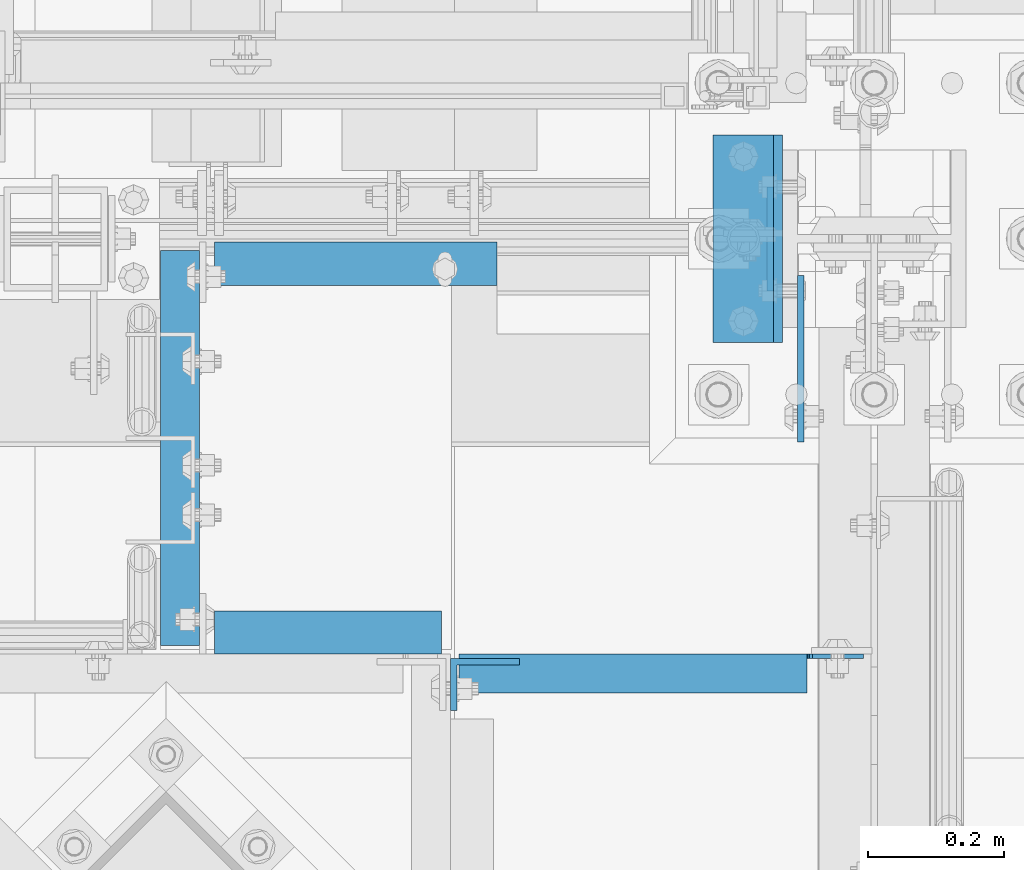
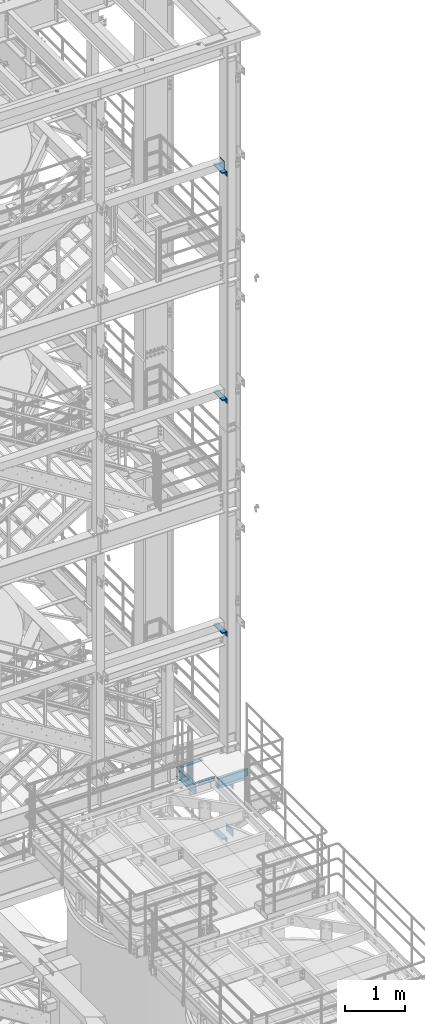
# One storey, part 1153 of 1876: 16 beams, 10 elements without a shape of their own.
"""IFC2X3 building model written with IfcOpenShell, lengths in millimetres."""

from ifc_helpers import new_model, si_unit, frame, origin_with_axes, place, context, subcontext, project, spatial, faceted_brep, material, type_object, element, aggregate, save


model = new_model("IFC2X3")

# Units and contexts
model_context = context("Model", 3, precision=1e-05, world=origin_with_axes())
body_context = subcontext(model_context, "Body", "Model", "MODEL_VIEW")
ifc_project = project(units=[si_unit("LENGTHUNIT", "METRE", prefix="MILLI"), si_unit("AREAUNIT", "SQUARE_METRE"), si_unit("VOLUMEUNIT", "CUBIC_METRE"), si_unit("MASSUNIT", "GRAM", prefix="KILO"), si_unit("TIMEUNIT", "SECOND"), si_unit("PLANEANGLEUNIT", "RADIAN"), si_unit("SOLIDANGLEUNIT", "STERADIAN"), si_unit("THERMODYNAMICTEMPERATUREUNIT", "DEGREE_CELSIUS"), si_unit("LUMINOUSINTENSITYUNIT", "LUMEN")], contexts=[model_context])

# Site, building, storey
site_placement = place(None, origin_with_axes())
site = spatial("IfcSite", under=ifc_project, at=site_placement, CompositionType="ELEMENT")
building_placement = place(site_placement, origin_with_axes())
building = spatial("IfcBuilding", under=site, at=building_placement, Name="Undefined", CompositionType="ELEMENT")
storey_placement = place(building_placement, origin_with_axes())
storey = spatial("IfcBuildingStorey", under=building, at=storey_placement, Name="Undefined", CompositionType="ELEMENT", Elevation=0.0)

# Assembly, beam
assembly_1_placement = place(storey_placement, origin_with_axes())
assembly_1 = element("IfcElementAssembly", 1, at=assembly_1_placement, inside=storey, Name="FRAME", AssemblyPlace="NOTDEFINED", PredefinedType="RIGID_FRAME")
ifc_material = material(Name="STEEL/A36")
beam_type_1 = type_object("IfcBeamType", PredefinedType="NOTDEFINED")
beam_1_placement = place(assembly_1_placement, frame((7467.60000019073, -7188.2, 19958.05), z_axis=(0.0, 0.0, -1.0), x_axis=(0.0, 1.0, 0.0)))
beam_1 = element("IfcBeam", 2, at=beam_1_placement, type_object=beam_type_1, material=ifc_material, Name="PLATE", context=body_context, shape_type="Brep", body=[
    faceted_brep([(0.0, 4.76249999999982, -76.1999999999998), (3.63797880709171e-12, 4.76249999999982, 76.1999969482422), (152.399993896484, 4.76250000000073, 76.1999969482422), (152.4, 4.76249999999982, -76.1999999999998), (3.63797880709171e-12, -4.76249999999982, 76.1999969482422), (152.399993896484, -4.76250000000073, 76.1999969482422), (0.0, -4.76249999999982, -76.1999999999998), (152.4, -4.76249999999982, -76.1999999999998)], [[[0, 1, 2, 3]], [[4, 5, 2, 1]], [[4, 6, 7, 5]], [[6, 0, 3, 7]], [[5, 7, 3, 2]], [[6, 4, 1, 0]]]),
])

# Assembly, beams
assembly_2_placement = place(storey_placement, origin_with_axes())
assembly_2 = element("IfcElementAssembly", 3, at=assembly_2_placement, inside=storey, Name="COLUMN", AssemblyPlace="NOTDEFINED", PredefinedType="RIGID_FRAME")
beam_2_placement = place(assembly_2_placement, frame((7512.05000642308, -7410.44999604537, 6483.35), z_axis=(0.0, 0.0, -1.0), x_axis=(0.0, 1.0, 0.0)))
beam_2 = element("IfcBeam", 4, at=beam_2_placement, type_object=beam_type_1, material=ifc_material, Name="PLATE", context=body_context, shape_type="Brep", body=[
    faceted_brep([(0.0, 4.76249999999982, -76.1999999999998), (3.63797880709171e-12, 4.76249999999982, 76.1999969482422), (244.474996168343, 4.76249999995889, 76.1999999999998), (244.474996168343, 4.76249999995889, -76.1999999999998), (3.63797880709171e-12, -4.76249999999982, 76.1999969482422), (244.474996168342, -4.76250000004075, 76.1999999999998), (0.0, -4.76249999999982, -76.1999999999998), (244.474996168342, -4.76250000004075, -76.1999999999998)], [[[0, 1, 2, 3]], [[1, 4, 5, 2]], [[4, 6, 7, 5]], [[6, 0, 3, 7]], [[5, 7, 3, 2]], [[6, 4, 1, 0]]]),
])
beam_3_placement = place(assembly_2_placement, frame((7512.05000642308, -7410.44999604537, 7454.9), z_axis=(0.0, 0.0, -1.0), x_axis=(0.0, 1.0, 0.0)))
beam_3 = element("IfcBeam", 5, at=beam_3_placement, type_object=beam_type_1, material=ifc_material, Name="PLATE", context=body_context, shape_type="Brep", body=[
    faceted_brep([(0.0, 4.76249999999982, -76.1999999999998), (3.63797880709171e-12, 4.76249999999982, 76.1999969482422), (244.474996168343, 4.76249999995889, 76.1999999999998), (244.474996168343, 4.76249999995889, -76.1999999999998), (3.63797880709171e-12, -4.76249999999982, 76.1999969482422), (244.474996168342, -4.76250000004075, 76.1999999999998), (0.0, -4.76249999999982, -76.1999999999998), (244.474996168342, -4.76250000004075, -76.1999999999998)], [[[0, 1, 2, 3]], [[1, 4, 5, 2]], [[4, 6, 7, 5]], [[6, 0, 3, 7]], [[5, 7, 3, 2]], [[6, 4, 1, 0]]]),
])

# Beam
beam_type_2 = type_object("IfcBeamType", PredefinedType="NOTDEFINED")
beam_4_placement = place(assembly_1_placement, frame((7427.91250019074, -7264.4, 19877.0875), z_axis=(-1.0, 0.0, 0.0), x_axis=(0.0, 1.0, 0.0)))
beam_4 = element("IfcBeam", 6, at=beam_4_placement, type_object=beam_type_2, material=ifc_material, Name="PLATE", context=body_context, shape_type="Brep", body=[
    faceted_brep([(0.0, 4.76250000000073, -44.4499999999998), (0.0, 4.76250000000073, 44.4499999999998), (304.799999999999, 4.76250000000073, 44.4499999999998), (304.799999999999, 4.76250000000073, -44.4499999999998), (0.0, -4.76250000000073, 44.4499999999998), (304.799999999999, -4.76250000000073, 44.4499999999998), (0.0, -4.76250000000073, -44.4499999999998), (304.799999999999, -4.76250000000073, -44.4499999999998)], [[[0, 1, 2, 3]], [[1, 4, 5, 2]], [[4, 6, 7, 5]], [[6, 0, 3, 7]], [[5, 7, 3, 2]], [[6, 4, 1, 0]]]),
])

aggregate(assembly_1, [beam_1, beam_4])

# Assembly, beam
assembly_3_placement = place(storey_placement, origin_with_axes())
assembly_3 = element("IfcElementAssembly", 7, at=assembly_3_placement, inside=storey, Name="FRAME", AssemblyPlace="NOTDEFINED", PredefinedType="RIGID_FRAME")
beam_5_placement = place(assembly_3_placement, frame((7427.91250019074, -7264.4, 15254.2875), z_axis=(-1.0, 0.0, 0.0), x_axis=(0.0, 1.0, 0.0)))
beam_5 = element("IfcBeam", 8, at=beam_5_placement, type_object=beam_type_2, material=ifc_material, Name="PLATE", context=body_context, shape_type="Brep", body=[
    faceted_brep([(0.0, 4.76250000000073, -44.4499999999998), (0.0, 4.76250000000073, 44.4499999999998), (304.799999999999, 4.76250000000073, 44.4499999999998), (304.799999999999, 4.76250000000073, -44.4499999999998), (0.0, -4.76250000000073, 44.4499999999998), (304.799999999999, -4.76250000000073, 44.4499999999998), (0.0, -4.76250000000073, -44.4499999999998), (304.799999999999, -4.76250000000073, -44.4499999999998)], [[[0, 1, 2, 3]], [[1, 4, 5, 2]], [[4, 6, 7, 5]], [[6, 0, 3, 7]], [[5, 7, 3, 2]], [[6, 4, 1, 0]]]),
])
aggregate(assembly_3, [beam_5])

assembly_4_placement = place(storey_placement, origin_with_axes())
assembly_4 = element("IfcElementAssembly", 9, at=assembly_4_placement, inside=storey, Name="FRAME", AssemblyPlace="NOTDEFINED", PredefinedType="RIGID_FRAME")
beam_6_placement = place(assembly_4_placement, frame((7427.93174253958, -7264.4, 10517.1875), z_axis=(-1.0, 0.0, 0.0), x_axis=(0.0, 1.0, 0.0)))
beam_6 = element("IfcBeam", 10, at=beam_6_placement, type_object=beam_type_2, material=ifc_material, Name="PLATE", context=body_context, shape_type="Brep", body=[
    faceted_brep([(0.0, 4.76250000000073, -44.4499999999998), (0.0, 4.76250000000073, 44.4499999999998), (304.799999999999, 4.76250000000073, 44.4499999999998), (304.799999999999, 4.76250000000073, -44.4499999999998), (0.0, -4.76250000000073, 44.4499999999998), (304.799999999999, -4.76250000000073, 44.4499999999998), (0.0, -4.76250000000073, -44.4499999999998), (304.799999999999, -4.76250000000073, -44.4499999999998)], [[[0, 1, 2, 3]], [[1, 4, 5, 2]], [[4, 6, 7, 5]], [[6, 0, 3, 7]], [[5, 7, 3, 2]], [[6, 4, 1, 0]]]),
])
aggregate(assembly_4, [beam_6])

assembly_5_placement = place(storey_placement, origin_with_axes())
assembly_5 = element("IfcElementAssembly", 11, at=assembly_5_placement, inside=storey, Name="FRAME", AssemblyPlace="NOTDEFINED", PredefinedType="RIGID_FRAME")
beam_7_placement = place(assembly_5_placement, frame((7427.89325746042, -7264.4, 6326.18751063849), z_axis=(-1.0, 0.0, 0.0), x_axis=(0.0, 1.0, 0.0)))
beam_7 = element("IfcBeam", 12, at=beam_7_placement, type_object=beam_type_2, material=ifc_material, Name="PLATE", context=body_context, shape_type="Brep", body=[
    faceted_brep([(0.0, 4.76250000000073, -44.4499999999998), (0.0, 4.76250000000073, 44.4499999999998), (304.799999999999, 4.76250000000073, 44.4499999999998), (304.799999999999, 4.76250000000073, -44.4499999999998), (0.0, -4.76250000000073, 44.4499999999998), (304.799999999999, -4.76250000000073, 44.4499999999998), (0.0, -4.76250000000073, -44.4499999999998), (304.799999999999, -4.76250000000073, -44.4499999999998)], [[[0, 1, 2, 3]], [[1, 4, 5, 2]], [[4, 6, 7, 5]], [[6, 0, 3, 7]], [[5, 7, 3, 2]], [[6, 4, 1, 0]]]),
])
aggregate(assembly_5, [beam_7])

# Assembly, beams
assembly_6_placement = place(storey_placement, origin_with_axes())
assembly_6 = element("IfcElementAssembly", 13, at=assembly_6_placement, inside=storey, Name="COLUMN", AssemblyPlace="NOTDEFINED", PredefinedType="RIGID_FRAME")
beam_type_3 = type_object("IfcBeamType", Name="L4X4X3/8", PredefinedType="NOTDEFINED")
beam_8_placement = place(assembly_6_placement, frame((7434.26250019074, -6959.6, 19821.525), z_axis=(-1.0, 0.0, 0.0), x_axis=(0.0, -1.0, 0.0)))
beam_8 = element("IfcBeam", 14, at=beam_8_placement, type_object=beam_type_3, material=ifc_material, Name="ANGLE", ObjectType="L4X4X3/8", context=body_context, shape_type="Brep", body=[
    faceted_brep([(0.0, 50.7999999999993, -50.8000000000002), (0.0, 50.7999999999993, 50.8000000000002), (304.799999999999, 50.7999999999993, 50.8000000000002), (304.799999999999, 50.7999999999993, -50.8000000000002), (0.0, 41.2750000000015, 50.8000000000002), (304.799999999999, 41.2750000000015, 50.8000000000002), (0.0, 41.2750000000015, -41.2749999999996), (304.799999999999, 41.2750000000015, -41.2749999999996), (0.0, -50.7999999999993, -41.2749999999996), (304.799999999999, -50.7999999999993, -41.2749999999996), (0.0, -50.7999999999993, -50.8000000000002), (304.799999999999, -50.7999999999993, -50.8000000000002)], [[[0, 1, 2, 3]], [[1, 4, 5, 2]], [[4, 6, 7, 5]], [[6, 8, 9, 7]], [[8, 10, 11, 9]], [[10, 0, 3, 11]], [[5, 7, 9, 11, 3, 2]], [[10, 8, 6, 4, 1, 0]]]),
])
beam_9_placement = place(assembly_6_placement, frame((7434.26250019074, -6959.6, 15198.725), z_axis=(-1.0, 0.0, 0.0), x_axis=(0.0, -1.0, 0.0)))
beam_9 = element("IfcBeam", 15, at=beam_9_placement, type_object=beam_type_3, material=ifc_material, Name="ANGLE", ObjectType="L4X4X3/8", context=body_context, shape_type="Brep", body=[
    faceted_brep([(0.0, 50.7999999999993, -50.8000000000002), (0.0, 50.7999999999993, 50.8000000000002), (304.799999999999, 50.7999999999993, 50.8000000000002), (304.799999999999, 50.7999999999993, -50.8000000000002), (0.0, 41.2750000000015, 50.8000000000002), (304.799999999999, 41.2750000000015, 50.8000000000002), (0.0, 41.2750000000015, -41.2749999999996), (304.799999999999, 41.2750000000015, -41.2749999999996), (0.0, -50.7999999999993, -41.2749999999996), (304.799999999999, -50.7999999999993, -41.2749999999996), (0.0, -50.7999999999993, -50.8000000000002), (304.799999999999, -50.7999999999993, -50.8000000000002)], [[[0, 1, 2, 3]], [[1, 4, 5, 2]], [[4, 6, 7, 5]], [[6, 8, 9, 7]], [[8, 10, 11, 9]], [[10, 0, 3, 11]], [[5, 7, 9, 11, 3, 2]], [[10, 8, 6, 4, 1, 0]]]),
])
aggregate(assembly_6, [beam_8, beam_9])

# Beam
beam_10_placement = place(assembly_2_placement, frame((7434.28174253958, -6959.6, 10461.625), z_axis=(-1.0, 0.0, 0.0), x_axis=(0.0, -1.0, 0.0)))
beam_10 = element("IfcBeam", 16, at=beam_10_placement, type_object=beam_type_3, material=ifc_material, Name="ANGLE", ObjectType="L4X4X3/8", context=body_context, shape_type="Brep", body=[
    faceted_brep([(0.0, 50.7999999999993, -50.8000000000002), (0.0, 50.7999999999993, 50.8000000000002), (304.799999999999, 50.7999999999993, 50.8000000000002), (304.799999999999, 50.7999999999993, -50.8000000000002), (0.0, 41.2750000000015, 50.8000000000002), (304.799999999999, 41.2750000000015, 50.8000000000002), (0.0, 41.2750000000015, -41.2749999999996), (304.799999999999, 41.2750000000015, -41.2749999999996), (0.0, -50.7999999999993, -41.2749999999996), (304.799999999999, -50.7999999999993, -41.2749999999996), (0.0, -50.7999999999993, -50.8000000000002), (304.799999999999, -50.7999999999993, -50.8000000000002)], [[[0, 1, 2, 3]], [[1, 4, 5, 2]], [[4, 6, 7, 5]], [[6, 8, 9, 7]], [[8, 10, 11, 9]], [[10, 0, 3, 11]], [[5, 7, 9, 11, 3, 2]], [[10, 8, 6, 4, 1, 0]]]),
])

beam_11_placement = place(assembly_2_placement, frame((7434.24325746042, -6959.6, 6270.62501063849), z_axis=(-1.0, 0.0, 0.0), x_axis=(0.0, -1.0, 0.0)))
beam_11 = element("IfcBeam", 17, at=beam_11_placement, type_object=beam_type_3, material=ifc_material, Name="ANGLE", ObjectType="L4X4X3/8", context=body_context, shape_type="Brep", body=[
    faceted_brep([(0.0, 50.7999999999993, -50.8000000000002), (0.0, 50.7999999999993, 50.8000000000002), (304.799999999999, 50.7999999999993, 50.8000000000002), (304.799999999999, 50.7999999999993, -50.8000000000002), (0.0, 41.2750000000015, 50.8000000000002), (304.799999999999, 41.2750000000015, 50.8000000000002), (0.0, 41.2750000000015, -41.2749999999996), (304.799999999999, 41.2750000000015, -41.2749999999996), (0.0, -50.7999999999993, -41.2749999999996), (304.799999999999, -50.7999999999993, -41.2749999999996), (0.0, -50.7999999999993, -50.8000000000002), (304.799999999999, -50.7999999999993, -50.8000000000002)], [[[0, 1, 2, 3]], [[1, 4, 5, 2]], [[4, 6, 7, 5]], [[6, 8, 9, 7]], [[8, 10, 11, 9]], [[10, 0, 3, 11]], [[5, 7, 9, 11, 3, 2]], [[10, 8, 6, 4, 1, 0]]]),
])

aggregate(assembly_2, [beam_10, beam_11, beam_2, beam_3])

# Assembly, beam
assembly_7_placement = place(storey_placement, origin_with_axes())
assembly_7 = element("IfcElementAssembly", 18, at=assembly_7_placement, inside=storey, Name="BEAM", AssemblyPlace="NOTDEFINED", PredefinedType="RIGID_FRAME")
beam_type_4 = type_object("IfcBeamType", Name="L2-1/2X2-1/2X1/4", PredefinedType="NOTDEFINED")
beam_12_placement = place(assembly_7_placement, frame((6651.625, -7148.5125, 7966.075), z_axis=(0.0, -1.0, 0.0), x_axis=(1.0, 0.0, 0.0)))
beam_12 = element("IfcBeam", 19, at=beam_12_placement, type_object=beam_type_4, material=ifc_material, Name="ANGLE", ObjectType="L2-1/2X2-1/2X1/4", context=body_context, shape_type="Brep", body=[
    faceted_brep([(0.0, 31.75, -31.75), (0.0, 31.75, 31.75), (414.337500000001, 31.75, 31.75), (414.337500000001, 31.75, -31.75), (0.0, 25.3999999999996, 31.75), (414.337500000001, 25.3999999999996, 31.75), (0.0, 25.3999999999996, -25.3999999999996), (414.337500000001, 25.3999999999996, -25.3999999999996), (0.0, -31.75, -25.3999999999996), (414.337500000001, -31.75, -25.3999999999996), (0.0, -31.75, -31.75), (414.337500000001, -31.75, -31.75)], [[[0, 1, 2, 3]], [[1, 4, 5, 2]], [[4, 6, 7, 5]], [[6, 8, 9, 7]], [[8, 10, 11, 9]], [[10, 0, 3, 11]], [[5, 7, 9, 11, 3, 2]], [[10, 8, 6, 4, 1, 0]]]),
])
aggregate(assembly_7, [beam_12])

assembly_8_placement = place(storey_placement, origin_with_axes())
assembly_8 = element("IfcElementAssembly", 20, at=assembly_8_placement, inside=storey, Name="BEAM", AssemblyPlace="NOTDEFINED", PredefinedType="RIGID_FRAME")
beam_13_placement = place(assembly_8_placement, frame((6651.61956383864, -7689.87148494434, 7966.075), z_axis=(0.0, 0.0, -1.0), x_axis=(0.999999985342198, 0.000171218000057581, 0.0)))
beam_13 = element("IfcBeam", 21, at=beam_13_placement, type_object=beam_type_4, material=ifc_material, Name="ANGLE", ObjectType="L2-1/2X2-1/2X1/4", context=body_context, shape_type="Brep", body=[
    faceted_brep([(0.0, 31.75, -31.75), (0.0, 31.75, 31.75), (333.377234371013, 31.7499999999964, 31.75), (333.377234371013, 31.7499999999964, -31.75), (0.0, 25.3999999999996, 31.75), (333.377234371013, 25.3999999999942, 31.75), (0.0, 25.3999999999996, -25.3999999999996), (333.377234371013, 25.3999999999942, -25.3999999999996), (0.0, -31.75, -25.3999999999996), (333.377234371011, -31.7500000000282, -25.3999999999996), (0.0, -31.75, -31.75), (333.377234371011, -31.7500000000282, -31.75)], [[[0, 1, 2, 3]], [[1, 4, 5, 2]], [[4, 6, 7, 5]], [[6, 8, 9, 7]], [[8, 10, 11, 9]], [[10, 0, 3, 11]], [[5, 7, 9, 11, 3, 2]], [[10, 8, 6, 4, 1, 0]]]),
])
aggregate(assembly_8, [beam_13])

assembly_9_placement = place(storey_placement, origin_with_axes())
assembly_9 = element("IfcElementAssembly", 22, at=assembly_9_placement, inside=storey, Name="BEAM", AssemblyPlace="NOTDEFINED", PredefinedType="RIGID_FRAME")
beam_type_5 = type_object("IfcBeamType", Name="C8X11.5", PredefinedType="NOTDEFINED")
beam_14_placement = place(assembly_9_placement, frame((6600.825, -7721.56440429563, 7896.225), z_axis=(0.0, 0.0, -1.0), x_axis=(0.0, 1.0, 0.0)))
beam_14 = element("IfcBeam", 23, at=beam_14_placement, type_object=beam_type_5, material=ifc_material, Name="BEAM", ObjectType="C8X11.5", context=body_context, shape_type="Brep", body=[
    faceted_brep([(12.7000000000007, 28.5749999999998, -101.6), (12.7000000000007, 28.5749999999998, 101.6), (592.10190429563, 28.5749999999998, 101.6), (592.10190429563, 28.5749999999998, -101.6), (12.7000000000007, -28.5749999999998, 101.6), (592.10190429563, -28.5749999999998, 101.6), (12.7000000000007, -28.5749999999998, 96.8355949999996), (592.10190429563, -28.5749999999998, 96.8355949999996), (12.7000000000007, 22.2250000000004, 88.3723149999996), (592.10190429563, 22.2250000000004, 88.3723149999996), (12.7000000000007, 22.2250000000004, -88.3723149999996), (592.10190429563, 22.2250000000004, -88.3723149999996), (12.7000000000007, -28.5749999999998, -96.8355949999996), (592.10190429563, -28.5749999999998, -96.8355949999996), (12.7000000000007, -28.5749999999998, -101.6), (592.10190429563, -28.5749999999998, -101.6)], [[[0, 1, 2, 3]], [[1, 4, 5, 2]], [[4, 6, 7, 5]], [[6, 8, 9, 7]], [[8, 10, 11, 9]], [[10, 12, 13, 11]], [[12, 14, 15, 13]], [[14, 0, 3, 15]], [[5, 7, 9, 11, 13, 15, 3, 2]], [[14, 12, 10, 8, 6, 4, 1, 0]]]),
])
aggregate(assembly_9, [beam_14])

# Assembly, beams
assembly_10_placement = place(storey_placement, origin_with_axes())
assembly_10 = element("IfcElementAssembly", 24, at=assembly_10_placement, inside=storey, Name="BEAM", AssemblyPlace="NOTDEFINED", PredefinedType="RIGID_FRAME")
beam_15_placement = place(assembly_10_placement, frame((6997.70047584742, -7750.13940429563, 7896.225), z_axis=(0.0, 0.0, 1.0), x_axis=(1.0, 0.0, 0.0)))
beam_15 = element("IfcBeam", 25, at=beam_15_placement, type_object=beam_type_5, material=ifc_material, Name="BEAM", ObjectType="C8X11.5", context=body_context, shape_type="Brep", body=[
    faceted_brep([(523.874524152585, -28.5750000000007, -96.8355949999996), (523.874524152585, -28.5750000000007, -101.6), (523.874524152585, 28.5750000000007, -101.6), (523.874524152585, 28.5750000000007, -88.899999809265), (523.874524152585, 19.0576241940871, -88.899999809265), (523.979487187225, 22.2250000000004, -88.3723149999996), (524.841254075172, 28.5750000000007, -84.0399202912195), (524.841254075172, 22.2250000000004, -84.0399202912195), (527.594267975651, 28.5750000000007, -79.9197438230658), (527.594267975651, 22.2250000000004, -79.9197438230658), (531.714444443804, 28.5750000000007, -77.1667299225874), (531.714444443804, 22.2250000000004, -77.1667299225874), (536.57452396185, 28.5750000000007, -76.1999999999998), (536.57452396185, 22.2250000000004, -76.1999999999998), (606.424524152584, 22.2250000000004, -76.1999999999998), (606.424524152584, 28.5750000000007, -76.1999999999998), (12.7000000000007, 28.5749999999998, 101.6), (12.7000000000007, -28.5749999999998, 101.6), (523.874524152585, -28.5750000000007, 101.6), (523.874524152585, 28.5750000000007, 101.6), (12.7000000000007, -28.5749999999998, -101.6), (12.7000000000007, -28.5749999999998, -96.8355949999996), (12.7000000000007, 22.2250000000004, -88.3723149999996), (12.7000000000007, 22.2250000000004, 88.3723149999996), (12.7000000000007, -28.5749999999998, 96.8355949999996), (12.7000000000007, 28.5749999999998, -101.6), (523.874524152585, -28.5750000000007, 96.8355949999996), (523.874524152585, 19.0576241940871, 88.899999809265), (523.874524152585, 28.5750000000007, 88.899999809265), (523.979487187226, 22.2250000000004, 88.3723149999996), (524.841254075172, 22.2250000000004, 84.0399202912195), (524.841254075172, 28.5750000000007, 84.0399202912195), (527.594267975651, 22.2250000000004, 79.9197438230658), (527.594267975651, 28.5750000000007, 79.9197438230658), (531.714444443804, 22.2250000000004, 77.1667299225874), (531.714444443804, 28.5750000000007, 77.1667299225874), (536.57452396185, 22.2250000000004, 76.1999999999998), (536.57452396185, 28.5750000000007, 76.1999999999998), (606.424524152584, 22.2250000000004, 76.1999999999998), (606.424524152584, 28.5750000000007, 76.1999999999998)], [[[0, 1, 2, 3, 4]], [[5, 4, 3, 6, 7]], [[7, 6, 8, 9]], [[9, 8, 10, 11]], [[11, 10, 12, 13]], [[14, 13, 12, 15]], [[16, 17, 18, 19]], [[20, 21, 22, 23, 24, 17, 16, 25]], [[17, 24, 26, 18]], [[18, 26, 27, 28, 19]], [[24, 23, 29, 27, 26]], [[30, 31, 28, 27, 29]], [[32, 33, 31, 30]], [[34, 35, 33, 32]], [[36, 37, 35, 34]], [[38, 39, 37, 36]], [[39, 38, 14, 15]], [[10, 8, 6, 3, 2, 25, 16, 19, 28, 31, 33, 35, 37, 39, 15, 12]], [[20, 25, 2, 1]], [[21, 20, 1, 0]], [[22, 21, 0, 4, 5]], [[38, 36, 34, 32, 30, 29, 23, 22, 5, 7, 9, 11, 13, 14]]]),
])
beam_type_6 = type_object("IfcBeamType", Name="L4X3X3/8", PredefinedType="NOTDEFINED")
beam_16_placement = place(assembly_10_placement, frame((7048.50047584742, -7766.01440429563, 7966.075), z_axis=(1.0, 0.0, 0.0), x_axis=(0.0, 0.0, -1.0)))
beam_16 = element("IfcBeam", 26, at=beam_16_placement, type_object=beam_type_6, material=ifc_material, Name="ANGLE", ObjectType="L4X3X3/8", context=body_context, shape_type="Brep", body=[
    faceted_brep([(0.0, 38.1000000000004, -50.8000000000002), (0.0, 38.1000000000004, 50.8000000000002), (139.7, 38.1000000000004, 50.8000000000002), (139.7, 38.1000000000004, -50.8000000000002), (0.0, 28.5749999999998, 50.8000000000002), (139.700000000001, 28.5749999999998, 50.8000000000002), (0.0, 28.5749999999998, -41.2749999999996), (139.700000000001, 28.5749999999998, -41.2749999999996), (0.0, -38.1000000000004, -41.2749999999996), (139.700000000001, -38.1000000000004, -41.2749999999996), (0.0, -38.1000000000004, -50.8000000000002), (139.7, -38.1000000000004, -50.8000000000002)], [[[0, 1, 2, 3]], [[1, 4, 5, 2]], [[4, 6, 7, 5]], [[6, 8, 9, 7]], [[8, 10, 11, 9]], [[10, 0, 3, 11]], [[5, 7, 9, 11, 3, 2]], [[10, 8, 6, 4, 1, 0]]]),
])
aggregate(assembly_10, [beam_16, beam_15])

save(model, "model.ifc")
